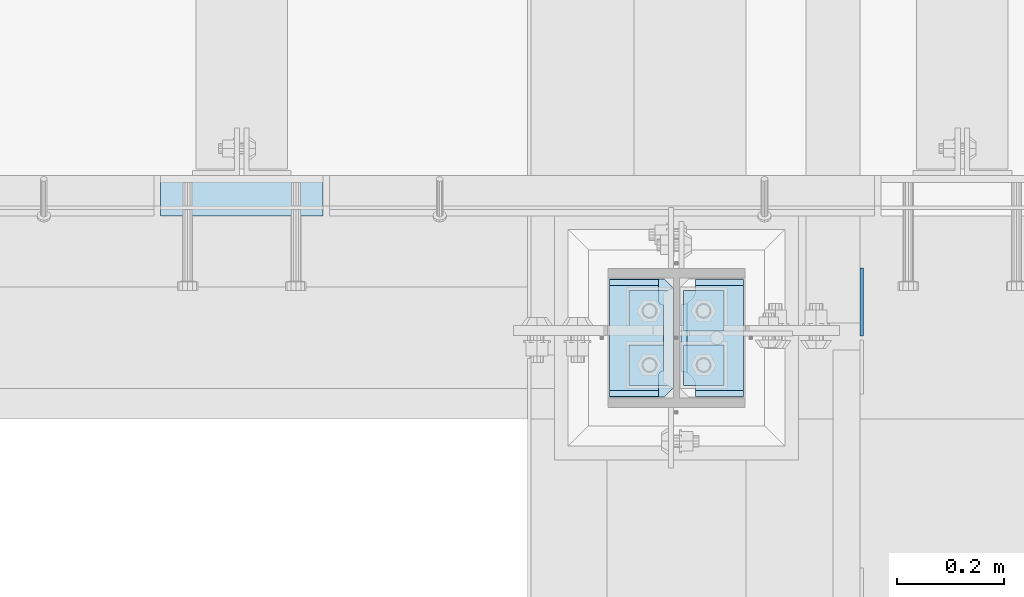
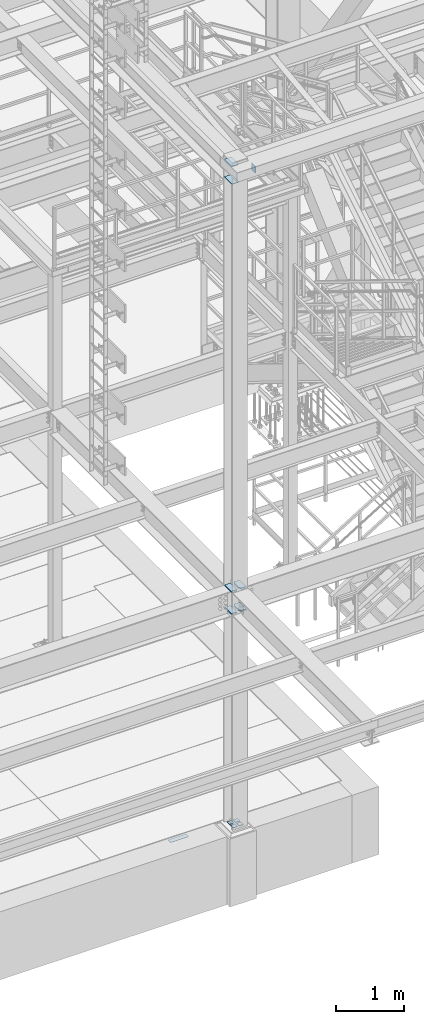
# One storey, part 3046 of 3843: 12 plates, 4 elements without a shape of their own.
"""IFC2X3 building model written with IfcOpenShell, lengths in millimetres."""

from ifc_helpers import new_model, si_unit, frame, origin_with_axes, place, context, subcontext, project, spatial, faceted_brep, material, type_object, element, aggregate, save


model = new_model("IFC2X3")

# Units and contexts
model_context = context("Model", 3, precision=1e-05, world=origin_with_axes())
body_context = subcontext(model_context, "Body", "Model", "MODEL_VIEW")
ifc_project = project(units=[si_unit("LENGTHUNIT", "METRE", prefix="MILLI"), si_unit("AREAUNIT", "SQUARE_METRE"), si_unit("VOLUMEUNIT", "CUBIC_METRE"), si_unit("MASSUNIT", "GRAM", prefix="KILO"), si_unit("TIMEUNIT", "SECOND"), si_unit("PLANEANGLEUNIT", "RADIAN"), si_unit("SOLIDANGLEUNIT", "STERADIAN"), si_unit("THERMODYNAMICTEMPERATUREUNIT", "DEGREE_CELSIUS"), si_unit("LUMINOUSINTENSITYUNIT", "LUMEN")], contexts=[model_context])

# Site, building, storey
site_placement = place(None, origin_with_axes())
site = spatial("IfcSite", under=ifc_project, at=site_placement, CompositionType="ELEMENT")
building_placement = place(site_placement, origin_with_axes())
building = spatial("IfcBuilding", under=site, at=building_placement, Name="Undefined", CompositionType="ELEMENT")
storey_placement = place(building_placement, origin_with_axes())
storey = spatial("IfcBuildingStorey", under=building, at=storey_placement, Name="Undefined", CompositionType="ELEMENT", Elevation=0.0)

# Assembly, plate
assembly_1_placement = place(storey_placement, origin_with_axes())
assembly_1 = element("IfcElementAssembly", 1, at=assembly_1_placement, inside=storey, Name="EMBED PLATE", AssemblyPlace="NOTDEFINED", PredefinedType="RIGID_FRAME")
ifc_material_1 = material(Name="STEEL/A36")
plate_type_1 = type_object("IfcPlateType", PredefinedType="NOTDEFINED")
plate_1_placement = place(assembly_1_placement, frame((48028.225, 15303.5000030518, 30400.625), z_axis=(1.0, 0.0, 0.0), x_axis=(0.0, -1.0, 0.0)))
plate_1 = element("IfcPlate", 2, at=plate_1_placement, type_object=plate_type_1, material=ifc_material_1, Name="PLATE", context=body_context, shape_type="Brep", body=[
    faceted_brep([(0.0, -3.17499999999927, 0.0), (0.0, -3.17499999999927, 304.800000000003), (0.0, 3.17499999999927, 304.800000000003), (0.0, 3.17499999999927, 0.0), (76.1999999999971, -3.17499999999927, 304.799999999996), (76.1999999999971, 3.17499999999927, 304.799999999996), (76.1999999999971, -3.17499999999927, 0.0), (76.1999999999971, 3.17499999999927, 0.0)], [[[0, 1, 2, 3]], [[1, 4, 5, 2]], [[4, 6, 7, 5]], [[6, 0, 3, 7]], [[5, 7, 3, 2]], [[6, 4, 1, 0]]]),
])
aggregate(assembly_1, [plate_1])

assembly_2_placement = place(storey_placement, origin_with_axes())
assembly_2 = element("IfcElementAssembly", 3, at=assembly_2_placement, inside=storey, Name="BEAM", AssemblyPlace="NOTDEFINED", PredefinedType="RIGID_FRAME")
ifc_material_2 = material(Name="STEEL/A572-50")
plate_type_2 = type_object("IfcPlateType", PredefinedType="NOTDEFINED")
plate_2_placement = place(assembly_2_placement, frame((49344.2625, 15002.66875, 42202.1), z_axis=(0.0, 0.0, -1.0), x_axis=(0.0, 1.0, 0.0)))
plate_2 = element("IfcPlate", 4, at=plate_2_placement, type_object=plate_type_2, material=ifc_material_2, Name="PLATE", context=body_context, shape_type="Brep", body=[
    faceted_brep([(0.0, -3.17499999999927, 0.0), (0.0, -3.17500000000291, 107.950000000004), (0.0, 3.17500000000291, 107.950000000004), (0.0, 3.17499999999927, 0.0), (19.0500000000029, -3.17500000000291, 127.0), (19.0500000000029, 3.17500000000291, 127.0), (127.0, -3.17500000000291, 127.0), (127.0, 3.17500000000291, 127.0), (127.0, -3.17500000000291, 0.0), (127.0, 3.17500000000291, 0.0)], [[[0, 1, 2, 3]], [[1, 4, 5, 2]], [[4, 6, 7, 5]], [[6, 8, 9, 7]], [[8, 0, 3, 9]], [[5, 7, 9, 3, 2]], [[8, 6, 4, 1, 0]]]),
])
aggregate(assembly_2, [plate_2])

# Assembly, plates
assembly_3_placement = place(storey_placement, origin_with_axes())
assembly_3 = element("IfcElementAssembly", 5, at=assembly_3_placement, inside=storey, Name="TEMPLATE", AssemblyPlace="NOTDEFINED", PredefinedType="RIGID_FRAME")
plate_type_3 = type_object("IfcPlateType", PredefinedType="NOTDEFINED")
plate_3_placement = place(assembly_3_placement, frame((48983.9, 14986.0, 30548.2625), z_axis=(-1.0, 0.0, 0.0), x_axis=(0.0, -1.0, 0.0)))
plate_3 = element("IfcPlate", 6, at=plate_3_placement, type_object=plate_type_3, material=ifc_material_2, Name="Washer Plate", context=body_context, shape_type="Brep", body=[
    faceted_brep([(0.0, -4.76249999999709, 0.0), (-3.49245965480804e-10, -4.76249999999709, 76.1999999999462), (-3.49245965480804e-10, 4.76249999999709, 76.1999999999462), (0.0, 4.76249999999709, 0.0), (76.1999893188477, -4.76249999999709, 76.1999969482422), (76.1999893188477, 4.76249999999709, 76.1999969482422), (76.2000000012922, -4.76250000000073, 7.27595761418343e-11), (76.2000000012922, 4.76250000000073, 7.27595761418343e-11)], [[[0, 1, 2, 3]], [[1, 4, 5, 2]], [[4, 6, 7, 5]], [[6, 0, 3, 7]], [[5, 7, 3, 2]], [[6, 4, 1, 0]]]),
])
plate_4_placement = place(assembly_3_placement, frame((49085.5, 14986.0, 30548.2625), z_axis=(-1.0, 0.0, 0.0), x_axis=(0.0, -1.0, 0.0)))
plate_4 = element("IfcPlate", 7, at=plate_4_placement, type_object=plate_type_3, material=ifc_material_2, Name="Washer Plate", context=body_context, shape_type="Brep", body=[
    faceted_brep([(0.0, -4.76249999999709, 0.0), (-3.49245965480804e-10, -4.76249999999709, 76.1999999999462), (-3.49245965480804e-10, 4.76249999999709, 76.1999999999462), (0.0, 4.76249999999709, 0.0), (76.1999893188477, -4.76249999999709, 76.1999969482422), (76.1999893188477, 4.76249999999709, 76.1999969482422), (76.2000000012922, -4.76250000000073, 7.27595761418343e-11), (76.2000000012922, 4.76250000000073, 7.27595761418343e-11)], [[[0, 1, 2, 3]], [[1, 4, 5, 2]], [[4, 6, 7, 5]], [[6, 0, 3, 7]], [[5, 7, 3, 2]], [[6, 4, 1, 0]]]),
])
plate_5_placement = place(assembly_3_placement, frame((48983.9, 15087.6, 30548.2625), z_axis=(-1.0, 0.0, 0.0), x_axis=(0.0, -1.0, 0.0)))
plate_5 = element("IfcPlate", 8, at=plate_5_placement, type_object=plate_type_3, material=ifc_material_2, Name="Washer Plate", context=body_context, shape_type="Brep", body=[
    faceted_brep([(0.0, -4.76249999999709, 0.0), (-3.49245965480804e-10, -4.76249999999709, 76.1999999999462), (-3.49245965480804e-10, 4.76249999999709, 76.1999999999462), (0.0, 4.76249999999709, 0.0), (76.1999893188477, -4.76249999999709, 76.1999969482422), (76.1999893188477, 4.76249999999709, 76.1999969482422), (76.2000000012922, -4.76250000000073, 7.27595761418343e-11), (76.2000000012922, 4.76250000000073, 7.27595761418343e-11)], [[[0, 1, 2, 3]], [[1, 4, 5, 2]], [[4, 6, 7, 5]], [[6, 0, 3, 7]], [[5, 7, 3, 2]], [[6, 4, 1, 0]]]),
])
plate_6_placement = place(assembly_3_placement, frame((49085.5, 15087.6, 30548.2625), z_axis=(-1.0, 0.0, 0.0), x_axis=(0.0, -1.0, 0.0)))
plate_6 = element("IfcPlate", 9, at=plate_6_placement, type_object=plate_type_3, material=ifc_material_2, Name="Washer Plate", context=body_context, shape_type="Brep", body=[
    faceted_brep([(0.0, -4.76249999999709, 0.0), (-3.49245965480804e-10, -4.76249999999709, 76.1999999999462), (-3.49245965480804e-10, 4.76249999999709, 76.1999999999462), (0.0, 4.76249999999709, 0.0), (76.1999893188477, -4.76249999999709, 76.1999969482422), (76.1999893188477, 4.76249999999709, 76.1999969482422), (76.2000000012922, -4.76250000000073, 7.27595761418343e-11), (76.2000000012922, 4.76250000000073, 7.27595761418343e-11)], [[[0, 1, 2, 3]], [[1, 4, 5, 2]], [[4, 6, 7, 5]], [[6, 0, 3, 7]], [[5, 7, 3, 2]], [[6, 4, 1, 0]]]),
])
aggregate(assembly_3, [plate_3, plate_4, plate_5, plate_6])

assembly_4_placement = place(storey_placement, origin_with_axes())
assembly_4 = element("IfcElementAssembly", 10, at=assembly_4_placement, inside=storey, Name="COLUMN", AssemblyPlace="NOTDEFINED", PredefinedType="RIGID_FRAME")
plate_type_4 = type_object("IfcPlateType", PredefinedType="NOTDEFINED")
plate_7_placement = place(assembly_4_placement, frame((48991.04375, 14887.575, 42121.1375), z_axis=(0.0, 1.0, 0.0), x_axis=(-1.0, 0.0, 0.0)))
plate_7 = element("IfcPlate", 11, at=plate_7_placement, type_object=plate_type_4, material=ifc_material_2, Name="PLATE", context=body_context, shape_type="Brep", body=[
    faceted_brep([(-1.45519152283669e-11, -4.76250000000073, 17.4624996184939), (0.0, -4.76249999999709, 204.78750038147), (0.0, 4.76249999999709, 204.78750038147), (-1.45519152283669e-11, 4.76250000000073, 17.4624996184939), (17.4624996185303, -4.76249999999709, 222.25), (17.4624996185303, 4.76249999999709, 222.25), (120.650001525879, -4.76249999999709, 222.25), (120.650001525879, 4.76249999999709, 222.25), (120.650001525879, -4.76249999999709, 0.0), (120.650001525879, 4.76249999999709, 0.0), (17.4624996186321, -4.76250000000073, 7.27595761418343e-12), (17.4624996186321, 4.76250000000073, 7.27595761418343e-12)], [[[0, 1, 2, 3]], [[1, 4, 5, 2]], [[4, 6, 7, 5]], [[6, 8, 9, 7]], [[8, 10, 11, 9]], [[10, 0, 3, 11]], [[5, 7, 9, 11, 3, 2]], [[10, 8, 6, 4, 1, 0]]]),
])
plate_8_placement = place(assembly_4_placement, frame((48991.04375, 14887.575, 42435.4625), z_axis=(0.0, 1.0, 0.0), x_axis=(-1.0, 0.0, 0.0)))
plate_8 = element("IfcPlate", 12, at=plate_8_placement, type_object=plate_type_4, material=ifc_material_2, Name="PLATE", context=body_context, shape_type="Brep", body=[
    faceted_brep([(-1.45519152283669e-11, -4.76250000000073, 17.4624996184939), (0.0, -4.76249999999709, 204.78750038147), (0.0, 4.76249999999709, 204.78750038147), (-1.45519152283669e-11, 4.76250000000073, 17.4624996184939), (17.4624996185303, -4.76249999999709, 222.25), (17.4624996185303, 4.76249999999709, 222.25), (120.650001525879, -4.76249999999709, 222.25), (120.650001525879, 4.76249999999709, 222.25), (120.650001525879, -4.76249999999709, 0.0), (120.650001525879, 4.76249999999709, 0.0), (17.4624996186321, -4.76250000000073, 7.27595761418343e-12), (17.4624996186321, 4.76250000000073, 7.27595761418343e-12)], [[[0, 1, 2, 3]], [[1, 4, 5, 2]], [[4, 6, 7, 5]], [[6, 8, 9, 7]], [[8, 10, 11, 9]], [[10, 0, 3, 11]], [[5, 7, 9, 11, 3, 2]], [[10, 8, 6, 4, 1, 0]]]),
])
plate_type_5 = type_object("IfcPlateType", PredefinedType="NOTDEFINED")
plate_9_placement = place(assembly_4_placement, frame((49122.80625, 14885.9875, 34401.125), z_axis=(0.0, 1.0, 0.0), x_axis=(-1.0, 0.0, 0.0)))
plate_9 = element("IfcPlate", 13, at=plate_9_placement, type_object=plate_type_5, material=ifc_material_2, Name="PLATE", context=body_context, shape_type="Brep", body=[
    faceted_brep([(106.476727860114, 9.52500000000146, 46.8512444583885), (106.476727860114, 9.52500000000146, 178.573758593369), (111.329276315162, 1.12013952965935, 176.101261660615), (117.47525004769, -9.52500000000146, 175.12783505074), (117.47525004769, -9.52500000000146, 50.2971680010178), (111.329276315162, 1.12013952965935, 49.3237413911429), (0.0, 9.52500000000146, 211.2519778601), (0.0, -9.52500000000146, 222.250500047679), (90.4875011444092, -9.52500000000146, 222.250500047679), (90.4875011444092, 9.52500000000146, 211.2519778601), (90.4875011444092, 9.52500000000146, 14.1740221398904), (90.4875011444092, -9.52500000000146, 3.17549995231093), (0.0, -9.52500000000146, 3.17549995231093), (0.0, 9.52500000000146, 14.1740221398904), (90.4875011444092, -9.52500000000146, 204.787504196167), (90.4875011444092, 9.52500000000146, 204.787504196167), (91.9637589903286, -9.52500000000146, 195.466778985452), (91.9637589903286, 9.52500000000146, 195.466778985452), (96.2480261244273, -9.52500000000146, 187.058431299673), (96.2480261244273, 9.52500000000146, 187.058431299673), (102.920928629384, -9.52500000000146, 180.385528794717), (102.920928629384, 9.52500000000146, 180.385528794717), (111.329276315162, -9.52500000000146, 176.101261660615), (111.329276315162, -9.52500000000146, 49.3237413911429), (102.920928629384, -9.52500000000146, 45.0394742570406), (102.920928629384, 9.52500000000146, 45.0394742570406), (96.2480261244273, -9.52500000000146, 38.3665717520853), (96.2480261244273, 9.52500000000146, 38.3665717520853), (91.9637589903286, -9.52500000000146, 29.9582240663058), (91.9637589903286, 9.52500000000146, 29.9582240663058), (90.4875011444092, -9.52500000000146, 20.6374988555908), (90.4875011444092, 9.52500000000146, 20.6374988555908)], [[[0, 1, 2, 3, 4, 5]], [[6, 7, 8, 9]], [[10, 11, 12, 13]], [[13, 12, 7, 6]], [[14, 15, 9, 8]], [[14, 16, 17, 15]], [[16, 18, 19, 17]], [[18, 20, 21, 19]], [[21, 20, 22, 2, 1]], [[22, 3, 2]], [[23, 5, 4]], [[23, 24, 25, 0, 5]], [[24, 26, 27, 25]], [[26, 28, 29, 27]], [[28, 30, 31, 29]], [[31, 30, 11, 10]], [[25, 27, 29, 31, 10, 13, 6, 9, 15, 17, 19, 21, 1, 0]], [[11, 30, 28, 26, 24, 23, 4, 3, 22, 20, 18, 16, 14, 8, 7, 12]]]),
])
plate_10_placement = place(assembly_4_placement, frame((49122.80625, 14885.9875, 34801.175), z_axis=(0.0, 1.0, 0.0), x_axis=(-1.0, 0.0, 0.0)))
plate_10 = element("IfcPlate", 14, at=plate_10_placement, type_object=plate_type_5, material=ifc_material_2, Name="PLATE", context=body_context, shape_type="Brep", body=[
    faceted_brep([(106.476727860114, 9.52500000000146, 46.8512444583885), (106.476727860114, 9.52500000000146, 178.573758593369), (111.329276315162, 1.12013952965935, 176.101261660615), (117.47525004769, -9.52500000000146, 175.12783505074), (117.47525004769, -9.52500000000146, 50.2971680010178), (111.329276315162, 1.12013952965935, 49.3237413911429), (0.0, 9.52500000000146, 211.2519778601), (0.0, -9.52500000000146, 222.250500047679), (90.4875011444092, -9.52500000000146, 222.250500047679), (90.4875011444092, 9.52500000000146, 211.2519778601), (90.4875011444092, 9.52500000000146, 14.1740221398904), (90.4875011444092, -9.52500000000146, 3.17549995231093), (0.0, -9.52500000000146, 3.17549995231093), (0.0, 9.52500000000146, 14.1740221398904), (90.4875011444092, -9.52500000000146, 204.787504196167), (90.4875011444092, 9.52500000000146, 204.787504196167), (91.9637589903286, -9.52500000000146, 195.466778985452), (91.9637589903286, 9.52500000000146, 195.466778985452), (96.2480261244273, -9.52500000000146, 187.058431299673), (96.2480261244273, 9.52500000000146, 187.058431299673), (102.920928629384, -9.52500000000146, 180.385528794717), (102.920928629384, 9.52500000000146, 180.385528794717), (111.329276315162, -9.52500000000146, 176.101261660615), (111.329276315162, -9.52500000000146, 49.3237413911429), (102.920928629384, -9.52500000000146, 45.0394742570406), (102.920928629384, 9.52500000000146, 45.0394742570406), (96.2480261244273, -9.52500000000146, 38.3665717520853), (96.2480261244273, 9.52500000000146, 38.3665717520853), (91.9637589903286, -9.52500000000146, 29.9582240663058), (91.9637589903286, 9.52500000000146, 29.9582240663058), (90.4875011444092, -9.52500000000146, 20.6374988555908), (90.4875011444092, 9.52500000000146, 20.6374988555908)], [[[0, 1, 2, 3, 4, 5]], [[6, 7, 8, 9]], [[10, 11, 12, 13]], [[13, 12, 7, 6]], [[14, 15, 9, 8]], [[14, 16, 17, 15]], [[16, 18, 19, 17]], [[18, 20, 21, 19]], [[21, 20, 22, 2, 1]], [[22, 3, 2]], [[23, 5, 4]], [[23, 24, 25, 0, 5]], [[24, 26, 27, 25]], [[26, 28, 29, 27]], [[28, 30, 31, 29]], [[31, 30, 11, 10]], [[25, 27, 29, 31, 10, 13, 6, 9, 15, 17, 19, 21, 1, 0]], [[11, 30, 28, 26, 24, 23, 4, 3, 22, 20, 18, 16, 14, 8, 7, 12]]]),
])
plate_type_6 = type_object("IfcPlateType", PredefinedType="NOTDEFINED")
plate_11_placement = place(assembly_4_placement, frame((48870.39375, 15111.4125, 34401.125), z_axis=(0.0, -1.0, 0.0), x_axis=(1.0, 0.0, 0.0)))
plate_11 = element("IfcPlate", 15, at=plate_11_placement, type_object=plate_type_6, material=ifc_material_2, Name="PLATE", context=body_context, shape_type="Brep", body=[
    faceted_brep([(0.0, 9.52500000000146, 211.2519778601), (0.0, -9.52500000000146, 222.250500047679), (92.0750003814683, -9.52500000000146, 222.250500047679), (92.0750003814683, 9.52500000000146, 211.2519778601), (92.0750003814683, 9.52500000000146, 14.1740221398904), (92.0750003814683, -9.52500000000146, 3.17549995231093), (0.0, -9.52500000000146, 3.17549995231093), (0.0, 9.52500000000146, 14.1740221398904), (92.0750003814683, -9.52500000000146, 184.150000381469), (92.0750003814683, 9.52500000000146, 184.150000381469), (92.8000478052636, -9.52500000000146, 180.504940834173), (92.8000478052636, 9.52500000000146, 180.504940834173), (94.8648081789361, -9.52500000000146, 177.414808560407), (94.8648081789361, 9.52500000000146, 177.414808560407), (97.9549404527061, -9.52500000000146, 175.35004818673), (97.9549404527061, 9.52500000000146, 175.35004818673), (101.599999999999, -9.52500000000146, 174.625000762939), (101.599999999999, 9.52500000000146, 174.625000762939), (101.599999999999, -9.52500000000146, 50.7999992370605), (101.599999999999, 9.52500000000146, 50.7999992370605), (97.9549404527061, -9.52500000000146, 50.0749518132689), (97.9549404527061, 9.52500000000146, 50.0749518132689), (94.8648081789361, -9.52500000000146, 48.0101914395927), (94.8648081789361, 9.52500000000146, 48.0101914395927), (92.8000478052636, -9.52500000000146, 44.9200591658264), (92.8000478052636, 9.52500000000146, 44.9200591658264), (92.0750003814683, -9.52500000000146, 41.2749996185303), (92.0750003814683, 9.52500000000146, 41.2749996185303)], [[[0, 1, 2, 3]], [[4, 5, 6, 7]], [[7, 6, 1, 0]], [[8, 9, 3, 2]], [[8, 10, 11, 9]], [[10, 12, 13, 11]], [[12, 14, 15, 13]], [[14, 16, 17, 15]], [[16, 18, 19, 17]], [[18, 20, 21, 19]], [[20, 22, 23, 21]], [[22, 24, 25, 23]], [[24, 26, 27, 25]], [[27, 26, 5, 4]], [[9, 11, 13, 15, 17, 19, 21, 23, 25, 27, 4, 7, 0, 3]], [[5, 26, 24, 22, 20, 18, 16, 14, 12, 10, 8, 2, 1, 6]]]),
])
plate_12_placement = place(assembly_4_placement, frame((48870.39375, 15111.4125, 34801.175), z_axis=(0.0, -1.0, 0.0), x_axis=(1.0, 0.0, 0.0)))
plate_12 = element("IfcPlate", 16, at=plate_12_placement, type_object=plate_type_6, material=ifc_material_2, Name="PLATE", context=body_context, shape_type="Brep", body=[
    faceted_brep([(0.0, 9.52500000000146, 211.2519778601), (0.0, -9.52500000000146, 222.250500047679), (92.0750003814683, -9.52500000000146, 222.250500047679), (92.0750003814683, 9.52500000000146, 211.2519778601), (92.0750003814683, 9.52500000000146, 14.1740221398904), (92.0750003814683, -9.52500000000146, 3.17549995231093), (0.0, -9.52500000000146, 3.17549995231093), (0.0, 9.52500000000146, 14.1740221398904), (92.0750003814683, -9.52500000000146, 184.150000381469), (92.0750003814683, 9.52500000000146, 184.150000381469), (92.8000478052636, -9.52500000000146, 180.504940834173), (92.8000478052636, 9.52500000000146, 180.504940834173), (94.8648081789361, -9.52500000000146, 177.414808560407), (94.8648081789361, 9.52500000000146, 177.414808560407), (97.9549404527061, -9.52500000000146, 175.35004818673), (97.9549404527061, 9.52500000000146, 175.35004818673), (101.599999999999, -9.52500000000146, 174.625000762939), (101.599999999999, 9.52500000000146, 174.625000762939), (101.599999999999, -9.52500000000146, 50.7999992370605), (101.599999999999, 9.52500000000146, 50.7999992370605), (97.9549404527061, -9.52500000000146, 50.0749518132689), (97.9549404527061, 9.52500000000146, 50.0749518132689), (94.8648081789361, -9.52500000000146, 48.0101914395927), (94.8648081789361, 9.52500000000146, 48.0101914395927), (92.8000478052636, -9.52500000000146, 44.9200591658264), (92.8000478052636, 9.52500000000146, 44.9200591658264), (92.0750003814683, -9.52500000000146, 41.2749996185303), (92.0750003814683, 9.52500000000146, 41.2749996185303)], [[[0, 1, 2, 3]], [[4, 5, 6, 7]], [[7, 6, 1, 0]], [[8, 9, 3, 2]], [[8, 10, 11, 9]], [[10, 12, 13, 11]], [[12, 14, 15, 13]], [[14, 16, 17, 15]], [[16, 18, 19, 17]], [[18, 20, 21, 19]], [[20, 22, 23, 21]], [[22, 24, 25, 23]], [[24, 26, 27, 25]], [[27, 26, 5, 4]], [[9, 11, 13, 15, 17, 19, 21, 23, 25, 27, 4, 7, 0, 3]], [[5, 26, 24, 22, 20, 18, 16, 14, 12, 10, 8, 2, 1, 6]]]),
])
aggregate(assembly_4, [plate_7, plate_8, plate_9, plate_10, plate_11, plate_12])

save(model, "model.ifc")
